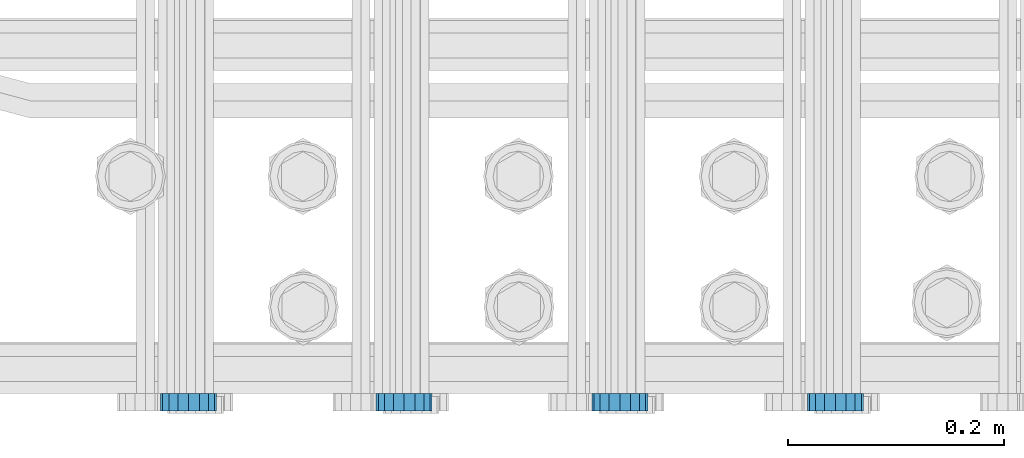
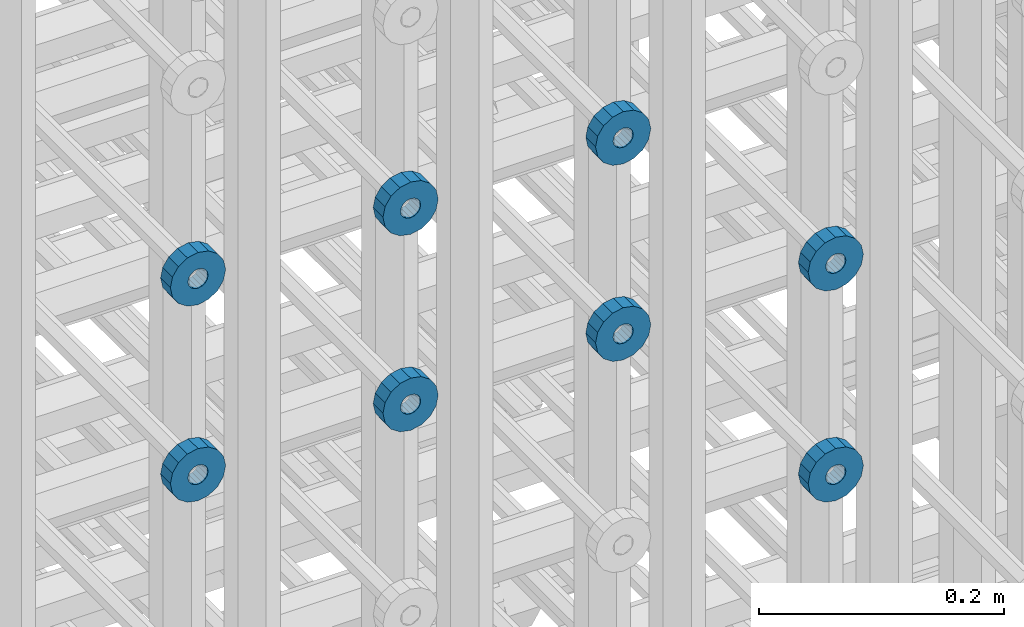
# One storey, part 117 of 177: 8 beams.
"""IFC2X3 building model written with IfcOpenShell, lengths in millimetres."""

from ifc_helpers import new_model, si_unit, frame, origin_with_axes, place, context, subcontext, project, spatial, faceted_brep, material, type_object, element, save


model = new_model("IFC2X3")

# Units and contexts
model_context_1 = context("Model", 3, precision=1e-05, world=origin_with_axes())
model_context_2 = context("Model", 3, precision=1e-05, world=origin_with_axes())
body_context = subcontext(model_context_2, "Body", "Model", "MODEL_VIEW")
ifc_project = project(units=[si_unit("LENGTHUNIT", "METRE", prefix="MILLI"), si_unit("AREAUNIT", "SQUARE_METRE"), si_unit("VOLUMEUNIT", "CUBIC_METRE"), si_unit("MASSUNIT", "GRAM", prefix="KILO"), si_unit("TIMEUNIT", "SECOND"), si_unit("PLANEANGLEUNIT", "RADIAN"), si_unit("SOLIDANGLEUNIT", "STERADIAN"), si_unit("THERMODYNAMICTEMPERATUREUNIT", "DEGREE_CELSIUS"), si_unit("LUMINOUSINTENSITYUNIT", "LUMEN")], contexts=[model_context_1])

# Site, building, storey
site_placement = place(None, origin_with_axes())
site = spatial("IfcSite", under=ifc_project, at=site_placement, CompositionType="ELEMENT")
building_placement = place(site_placement, origin_with_axes())
building = spatial("IfcBuilding", under=site, at=building_placement, Name="Undefined", CompositionType="ELEMENT")
storey_placement = place(building_placement, origin_with_axes())
storey = spatial("IfcBuildingStorey", under=building, at=storey_placement, Name="Undefined", CompositionType="ELEMENT", Elevation=0.0)

# Beams
ifc_material = material(Name="STEEL/Steel_Undefined")
beam_type = type_object("IfcBeamType", PredefinedType="NOTDEFINED")
beam_1_placement = place(storey_placement, frame((2030529.49847313, 6205075.98588032, 21954.9868114202), z_axis=(0.0, 0.0, -1.0), x_axis=(0.0, -1.0, 0.0)))
element("IfcBeam", 1, at=beam_1_placement, inside=storey, type_object=beam_type, material=ifc_material, context=body_context, shape_type="Brep", body=[
    faceted_brep([(0.0, -9.5, 0.0), (0.0, -8.77685555908829, 3.63549260746731), (16.0, -8.77685555908829, 3.63549260746731), (16.0, -9.5, 0.0), (0.0, -6.71751442085952, 6.71751442127061), (16.0, -6.71751442085952, 6.71751442127061), (0.0, -3.63549260701984, 8.77685555885546), (16.0, -3.63549260701984, 8.77685555885546), (-2.02452244836415e-12, 0.0, 9.5), (16.0, 0.0, 9.5), (0.0, 3.63549260701984, 8.77685555885546), (16.0, 3.63549260701984, 8.77685555885546), (0.0, 6.71751442085952, 6.71751442127061), (16.0, 6.71751442085952, 6.71751442127061), (0.0, 8.77685555908829, 3.63549260746731), (16.0, 8.77685555908829, 3.63549260746731), (0.0, 9.5, 0.0), (16.0, 9.5, 0.0), (0.0, 8.77685555908829, -3.63549260746731), (16.0, 8.77685555908829, -3.63549260746731), (0.0, 6.71751442085952, -6.71751442127061), (16.0, 6.71751442085952, -6.71751442127061), (0.0, 3.63549260701984, -8.77685555885546), (16.0, 3.63549260701984, -8.77685555885546), (2.02452244836415e-12, -3.69149155687865e-15, -9.5), (16.0, 0.0, -9.5), (0.0, -3.63549260701984, -8.77685555885546), (16.0, -3.63549260701984, -8.77685555885546), (0.0, -6.71751442085952, -6.71751442127061), (16.0, -6.71751442085952, -6.71751442127061), (0.0, -8.77685555908829, -3.63549260746731), (16.0, -8.77685555908829, -3.63549260746731), (0.0, -26.0, 0.0), (0.0, -24.0208678450435, -9.94976924149159), (16.0, -24.0208678450435, -9.94976924149159), (16.0, -26.0, 0.0), (0.0, -18.3847763109952, -18.3847763108497), (16.0, -18.3847763109952, -18.3847763108497), (0.0, -9.94976924173534, -24.0208678452946), (16.0, -9.94976924173534, -24.0208678452946), (0.0, 0.0, -26.0), (16.0, 0.0, -26.0), (0.0, 9.94976924173534, -24.0208678452946), (16.0, 9.94976924173534, -24.0208678452946), (0.0, 18.3847763109952, -18.3847763108497), (16.0, 18.3847763109952, -18.3847763108497), (0.0, 24.0208678450435, -9.94976924149159), (16.0, 24.0208678450435, -9.94976924149159), (0.0, 26.0, 0.0), (16.0, 26.0, 0.0), (0.0, 24.0208678450435, 9.94976924149159), (16.0, 24.0208678450435, 9.94976924149159), (0.0, 18.3847763109952, 18.3847763108497), (16.0, 18.3847763109952, 18.3847763108497), (0.0, 9.94976924173534, 24.0208678452946), (16.0, 9.94976924173534, 24.0208678452946), (0.0, 0.0, 26.0), (16.0, 0.0, 26.0), (0.0, -9.94976924173534, 24.0208678452946), (16.0, -9.94976924173534, 24.0208678452946), (0.0, -18.3847763109952, 18.3847763108497), (16.0, -18.3847763109952, 18.3847763108497), (0.0, -24.0208678450435, 9.94976924149159), (16.0, -24.0208678450435, 9.94976924149159)], [[[0, 1, 2, 3]], [[1, 4, 5, 2]], [[4, 6, 7, 5]], [[6, 8, 9, 7]], [[8, 10, 11, 9]], [[10, 12, 13, 11]], [[12, 14, 15, 13]], [[14, 16, 17, 15]], [[16, 18, 19, 17]], [[18, 20, 21, 19]], [[20, 22, 23, 21]], [[22, 24, 25, 23]], [[24, 26, 27, 25]], [[26, 28, 29, 27]], [[28, 30, 31, 29]], [[30, 0, 3, 31]], [[32, 33, 34, 35]], [[33, 36, 37, 34]], [[36, 38, 39, 37]], [[38, 40, 41, 39]], [[40, 42, 43, 41]], [[42, 44, 45, 43]], [[44, 46, 47, 45]], [[46, 48, 49, 47]], [[48, 50, 51, 49]], [[50, 52, 53, 51]], [[52, 54, 55, 53]], [[54, 56, 57, 55]], [[56, 58, 59, 57]], [[58, 60, 61, 59]], [[60, 62, 63, 61]], [[62, 32, 35, 63]], [[37, 39, 41, 43, 45, 47, 49, 51, 53, 55, 57, 59, 61, 63, 35, 34], [5, 7, 9, 11, 13, 15, 17, 19, 21, 23, 25, 27, 29, 31, 3, 2]], [[62, 60, 58, 56, 54, 52, 50, 48, 46, 44, 42, 40, 38, 36, 33, 32], [30, 28, 26, 24, 22, 20, 18, 16, 14, 12, 10, 8, 6, 4, 1, 0]]]),
])
beam_2_placement = place(storey_placement, frame((2030329.49847313, 6205075.98588032, 21954.9868114202), z_axis=(0.0, 0.0, -1.0), x_axis=(0.0, -1.0, 0.0)))
element("IfcBeam", 2, at=beam_2_placement, inside=storey, type_object=beam_type, material=ifc_material, context=body_context, shape_type="Brep", body=[
    faceted_brep([(0.0, -9.5, 0.0), (0.0, -8.77685555908829, 3.63549260746731), (16.0, -8.77685555908829, 3.63549260746731), (16.0, -9.5, 0.0), (0.0, -6.71751442085952, 6.71751442127061), (16.0, -6.71751442085952, 6.71751442127061), (0.0, -3.63549260701984, 8.77685555885546), (16.0, -3.63549260701984, 8.77685555885546), (-2.02452244836415e-12, 0.0, 9.5), (16.0, 0.0, 9.5), (0.0, 3.63549260701984, 8.77685555885546), (16.0, 3.63549260701984, 8.77685555885546), (0.0, 6.71751442085952, 6.71751442127061), (16.0, 6.71751442085952, 6.71751442127061), (0.0, 8.77685555908829, 3.63549260746731), (16.0, 8.77685555908829, 3.63549260746731), (0.0, 9.5, 0.0), (16.0, 9.5, 0.0), (0.0, 8.77685555908829, -3.63549260746731), (16.0, 8.77685555908829, -3.63549260746731), (0.0, 6.71751442085952, -6.71751442127061), (16.0, 6.71751442085952, -6.71751442127061), (0.0, 3.63549260701984, -8.77685555885546), (16.0, 3.63549260701984, -8.77685555885546), (2.02452244836415e-12, -3.69149155687865e-15, -9.5), (16.0, 0.0, -9.5), (0.0, -3.63549260701984, -8.77685555885546), (16.0, -3.63549260701984, -8.77685555885546), (0.0, -6.71751442085952, -6.71751442127061), (16.0, -6.71751442085952, -6.71751442127061), (0.0, -8.77685555908829, -3.63549260746731), (16.0, -8.77685555908829, -3.63549260746731), (0.0, -26.0, 0.0), (0.0, -24.0208678450435, -9.94976924149159), (16.0, -24.0208678450435, -9.94976924149159), (16.0, -26.0, 0.0), (0.0, -18.3847763109952, -18.3847763108497), (16.0, -18.3847763109952, -18.3847763108497), (0.0, -9.94976924173534, -24.0208678452946), (16.0, -9.94976924173534, -24.0208678452946), (0.0, 0.0, -26.0), (16.0, 0.0, -26.0), (0.0, 9.94976924173534, -24.0208678452946), (16.0, 9.94976924173534, -24.0208678452946), (0.0, 18.3847763109952, -18.3847763108497), (16.0, 18.3847763109952, -18.3847763108497), (0.0, 24.0208678450435, -9.94976924149159), (16.0, 24.0208678450435, -9.94976924149159), (0.0, 26.0, 0.0), (16.0, 26.0, 0.0), (0.0, 24.0208678450435, 9.94976924149159), (16.0, 24.0208678450435, 9.94976924149159), (0.0, 18.3847763109952, 18.3847763108497), (16.0, 18.3847763109952, 18.3847763108497), (0.0, 9.94976924173534, 24.0208678452946), (16.0, 9.94976924173534, 24.0208678452946), (0.0, 0.0, 26.0), (16.0, 0.0, 26.0), (0.0, -9.94976924173534, 24.0208678452946), (16.0, -9.94976924173534, 24.0208678452946), (0.0, -18.3847763109952, 18.3847763108497), (16.0, -18.3847763109952, 18.3847763108497), (0.0, -24.0208678450435, 9.94976924149159), (16.0, -24.0208678450435, 9.94976924149159)], [[[0, 1, 2, 3]], [[1, 4, 5, 2]], [[4, 6, 7, 5]], [[6, 8, 9, 7]], [[8, 10, 11, 9]], [[10, 12, 13, 11]], [[12, 14, 15, 13]], [[14, 16, 17, 15]], [[16, 18, 19, 17]], [[18, 20, 21, 19]], [[20, 22, 23, 21]], [[22, 24, 25, 23]], [[24, 26, 27, 25]], [[26, 28, 29, 27]], [[28, 30, 31, 29]], [[30, 0, 3, 31]], [[32, 33, 34, 35]], [[33, 36, 37, 34]], [[36, 38, 39, 37]], [[38, 40, 41, 39]], [[40, 42, 43, 41]], [[42, 44, 45, 43]], [[44, 46, 47, 45]], [[46, 48, 49, 47]], [[48, 50, 51, 49]], [[50, 52, 53, 51]], [[52, 54, 55, 53]], [[54, 56, 57, 55]], [[56, 58, 59, 57]], [[58, 60, 61, 59]], [[60, 62, 63, 61]], [[62, 32, 35, 63]], [[37, 39, 41, 43, 45, 47, 49, 51, 53, 55, 57, 59, 61, 63, 35, 34], [5, 7, 9, 11, 13, 15, 17, 19, 21, 23, 25, 27, 29, 31, 3, 2]], [[62, 60, 58, 56, 54, 52, 50, 48, 46, 44, 42, 40, 38, 36, 33, 32], [30, 28, 26, 24, 22, 20, 18, 16, 14, 12, 10, 8, 6, 4, 1, 0]]]),
])
beam_3_placement = place(storey_placement, frame((2030129.49847313, 6205075.98588032, 21954.9868114202), z_axis=(0.0, 0.0, -1.0), x_axis=(0.0, -1.0, 0.0)))
element("IfcBeam", 3, at=beam_3_placement, inside=storey, type_object=beam_type, material=ifc_material, context=body_context, shape_type="Brep", body=[
    faceted_brep([(0.0, -9.5, 0.0), (0.0, -8.77685555908829, 3.63549260746731), (16.0, -8.77685555908829, 3.63549260746731), (16.0, -9.5, 0.0), (0.0, -6.71751442085952, 6.71751442127061), (16.0, -6.71751442085952, 6.71751442127061), (0.0, -3.63549260701984, 8.77685555885546), (16.0, -3.63549260701984, 8.77685555885546), (-2.02452244836415e-12, 0.0, 9.5), (16.0, 0.0, 9.5), (0.0, 3.63549260701984, 8.77685555885546), (16.0, 3.63549260701984, 8.77685555885546), (0.0, 6.71751442085952, 6.71751442127061), (16.0, 6.71751442085952, 6.71751442127061), (0.0, 8.77685555908829, 3.63549260746731), (16.0, 8.77685555908829, 3.63549260746731), (0.0, 9.5, 0.0), (16.0, 9.5, 0.0), (0.0, 8.77685555908829, -3.63549260746731), (16.0, 8.77685555908829, -3.63549260746731), (0.0, 6.71751442085952, -6.71751442127061), (16.0, 6.71751442085952, -6.71751442127061), (0.0, 3.63549260701984, -8.77685555885546), (16.0, 3.63549260701984, -8.77685555885546), (2.02452244836415e-12, -3.69149155687865e-15, -9.5), (16.0, 0.0, -9.5), (0.0, -3.63549260701984, -8.77685555885546), (16.0, -3.63549260701984, -8.77685555885546), (0.0, -6.71751442085952, -6.71751442127061), (16.0, -6.71751442085952, -6.71751442127061), (0.0, -8.77685555908829, -3.63549260746731), (16.0, -8.77685555908829, -3.63549260746731), (0.0, -26.0, 0.0), (0.0, -24.0208678450435, -9.94976924149159), (16.0, -24.0208678450435, -9.94976924149159), (16.0, -26.0, 0.0), (0.0, -18.3847763109952, -18.3847763108497), (16.0, -18.3847763109952, -18.3847763108497), (0.0, -9.94976924173534, -24.0208678452946), (16.0, -9.94976924173534, -24.0208678452946), (0.0, 0.0, -26.0), (16.0, 0.0, -26.0), (0.0, 9.94976924173534, -24.0208678452946), (16.0, 9.94976924173534, -24.0208678452946), (0.0, 18.3847763109952, -18.3847763108497), (16.0, 18.3847763109952, -18.3847763108497), (0.0, 24.0208678450435, -9.94976924149159), (16.0, 24.0208678450435, -9.94976924149159), (0.0, 26.0, 0.0), (16.0, 26.0, 0.0), (0.0, 24.0208678450435, 9.94976924149159), (16.0, 24.0208678450435, 9.94976924149159), (0.0, 18.3847763109952, 18.3847763108497), (16.0, 18.3847763109952, 18.3847763108497), (0.0, 9.94976924173534, 24.0208678452946), (16.0, 9.94976924173534, 24.0208678452946), (0.0, 0.0, 26.0), (16.0, 0.0, 26.0), (0.0, -9.94976924173534, 24.0208678452946), (16.0, -9.94976924173534, 24.0208678452946), (0.0, -18.3847763109952, 18.3847763108497), (16.0, -18.3847763109952, 18.3847763108497), (0.0, -24.0208678450435, 9.94976924149159), (16.0, -24.0208678450435, 9.94976924149159)], [[[0, 1, 2, 3]], [[1, 4, 5, 2]], [[4, 6, 7, 5]], [[6, 8, 9, 7]], [[8, 10, 11, 9]], [[10, 12, 13, 11]], [[12, 14, 15, 13]], [[14, 16, 17, 15]], [[16, 18, 19, 17]], [[18, 20, 21, 19]], [[20, 22, 23, 21]], [[22, 24, 25, 23]], [[24, 26, 27, 25]], [[26, 28, 29, 27]], [[28, 30, 31, 29]], [[30, 0, 3, 31]], [[32, 33, 34, 35]], [[33, 36, 37, 34]], [[36, 38, 39, 37]], [[38, 40, 41, 39]], [[40, 42, 43, 41]], [[42, 44, 45, 43]], [[44, 46, 47, 45]], [[46, 48, 49, 47]], [[48, 50, 51, 49]], [[50, 52, 53, 51]], [[52, 54, 55, 53]], [[54, 56, 57, 55]], [[56, 58, 59, 57]], [[58, 60, 61, 59]], [[60, 62, 63, 61]], [[62, 32, 35, 63]], [[37, 39, 41, 43, 45, 47, 49, 51, 53, 55, 57, 59, 61, 63, 35, 34], [5, 7, 9, 11, 13, 15, 17, 19, 21, 23, 25, 27, 29, 31, 3, 2]], [[62, 60, 58, 56, 54, 52, 50, 48, 46, 44, 42, 40, 38, 36, 33, 32], [30, 28, 26, 24, 22, 20, 18, 16, 14, 12, 10, 8, 6, 4, 1, 0]]]),
])
beam_4_placement = place(storey_placement, frame((2030729.49847313, 6205075.98588607, 21759.9868126721), z_axis=(0.0, 0.0, -1.0), x_axis=(0.0, -1.0, 0.0)))
element("IfcBeam", 4, at=beam_4_placement, inside=storey, type_object=beam_type, material=ifc_material, context=body_context, shape_type="Brep", body=[
    faceted_brep([(0.0, -9.5, 0.0), (0.0, -8.77685555908829, 3.63549260746731), (16.0, -8.77685555908829, 3.63549260746731), (16.0, -9.5, 0.0), (0.0, -6.71751442085952, 6.71751442127061), (16.0, -6.71751442085952, 6.71751442127061), (0.0, -3.63549260701984, 8.77685555885546), (16.0, -3.63549260701984, 8.77685555885546), (-2.02452244836415e-12, 0.0, 9.5), (16.0, 0.0, 9.5), (0.0, 3.63549260701984, 8.77685555885546), (16.0, 3.63549260701984, 8.77685555885546), (0.0, 6.71751442085952, 6.71751442127061), (16.0, 6.71751442085952, 6.71751442127061), (0.0, 8.77685555908829, 3.63549260746731), (16.0, 8.77685555908829, 3.63549260746731), (0.0, 9.5, 0.0), (16.0, 9.5, 0.0), (0.0, 8.77685555908829, -3.63549260746731), (16.0, 8.77685555908829, -3.63549260746731), (0.0, 6.71751442085952, -6.71751442127061), (16.0, 6.71751442085952, -6.71751442127061), (0.0, 3.63549260701984, -8.77685555885546), (16.0, 3.63549260701984, -8.77685555885546), (2.02452244836415e-12, -3.69149155687865e-15, -9.5), (16.0, 0.0, -9.5), (0.0, -3.63549260701984, -8.77685555885546), (16.0, -3.63549260701984, -8.77685555885546), (0.0, -6.71751442085952, -6.71751442127061), (16.0, -6.71751442085952, -6.71751442127061), (0.0, -8.77685555908829, -3.63549260746731), (16.0, -8.77685555908829, -3.63549260746731), (0.0, -26.0, 0.0), (0.0, -24.0208678450435, -9.94976924149159), (16.0, -24.0208678450435, -9.94976924149159), (16.0, -26.0, 0.0), (0.0, -18.3847763109952, -18.3847763108497), (16.0, -18.3847763109952, -18.3847763108497), (0.0, -9.94976924173534, -24.0208678452946), (16.0, -9.94976924173534, -24.0208678452946), (0.0, 0.0, -26.0), (16.0, 0.0, -26.0), (0.0, 9.94976924173534, -24.0208678452946), (16.0, 9.94976924173534, -24.0208678452946), (0.0, 18.3847763109952, -18.3847763108497), (16.0, 18.3847763109952, -18.3847763108497), (0.0, 24.0208678450435, -9.94976924149159), (16.0, 24.0208678450435, -9.94976924149159), (0.0, 26.0, 0.0), (16.0, 26.0, 0.0), (0.0, 24.0208678450435, 9.94976924149159), (16.0, 24.0208678450435, 9.94976924149159), (0.0, 18.3847763109952, 18.3847763108497), (16.0, 18.3847763109952, 18.3847763108497), (0.0, 9.94976924173534, 24.0208678452946), (16.0, 9.94976924173534, 24.0208678452946), (0.0, 0.0, 26.0), (16.0, 0.0, 26.0), (0.0, -9.94976924173534, 24.0208678452946), (16.0, -9.94976924173534, 24.0208678452946), (0.0, -18.3847763109952, 18.3847763108497), (16.0, -18.3847763109952, 18.3847763108497), (0.0, -24.0208678450435, 9.94976924149159), (16.0, -24.0208678450435, 9.94976924149159)], [[[0, 1, 2, 3]], [[1, 4, 5, 2]], [[4, 6, 7, 5]], [[6, 8, 9, 7]], [[8, 10, 11, 9]], [[10, 12, 13, 11]], [[12, 14, 15, 13]], [[14, 16, 17, 15]], [[16, 18, 19, 17]], [[18, 20, 21, 19]], [[20, 22, 23, 21]], [[22, 24, 25, 23]], [[24, 26, 27, 25]], [[26, 28, 29, 27]], [[28, 30, 31, 29]], [[30, 0, 3, 31]], [[32, 33, 34, 35]], [[33, 36, 37, 34]], [[36, 38, 39, 37]], [[38, 40, 41, 39]], [[40, 42, 43, 41]], [[42, 44, 45, 43]], [[44, 46, 47, 45]], [[46, 48, 49, 47]], [[48, 50, 51, 49]], [[50, 52, 53, 51]], [[52, 54, 55, 53]], [[54, 56, 57, 55]], [[56, 58, 59, 57]], [[58, 60, 61, 59]], [[60, 62, 63, 61]], [[62, 32, 35, 63]], [[37, 39, 41, 43, 45, 47, 49, 51, 53, 55, 57, 59, 61, 63, 35, 34], [5, 7, 9, 11, 13, 15, 17, 19, 21, 23, 25, 27, 29, 31, 3, 2]], [[62, 60, 58, 56, 54, 52, 50, 48, 46, 44, 42, 40, 38, 36, 33, 32], [30, 28, 26, 24, 22, 20, 18, 16, 14, 12, 10, 8, 6, 4, 1, 0]]]),
])
beam_5_placement = place(storey_placement, frame((2030529.49847313, 6205075.98588607, 21759.9868126721), z_axis=(0.0, 0.0, -1.0), x_axis=(0.0, -1.0, 0.0)))
element("IfcBeam", 5, at=beam_5_placement, inside=storey, type_object=beam_type, material=ifc_material, context=body_context, shape_type="Brep", body=[
    faceted_brep([(0.0, -9.5, 0.0), (0.0, -8.77685555908829, 3.63549260746731), (16.0, -8.77685555908829, 3.63549260746731), (16.0, -9.5, 0.0), (0.0, -6.71751442085952, 6.71751442127061), (16.0, -6.71751442085952, 6.71751442127061), (0.0, -3.63549260701984, 8.77685555885546), (16.0, -3.63549260701984, 8.77685555885546), (-2.02452244836415e-12, 0.0, 9.5), (16.0, 0.0, 9.5), (0.0, 3.63549260701984, 8.77685555885546), (16.0, 3.63549260701984, 8.77685555885546), (0.0, 6.71751442085952, 6.71751442127061), (16.0, 6.71751442085952, 6.71751442127061), (0.0, 8.77685555908829, 3.63549260746731), (16.0, 8.77685555908829, 3.63549260746731), (0.0, 9.5, 0.0), (16.0, 9.5, 0.0), (0.0, 8.77685555908829, -3.63549260746731), (16.0, 8.77685555908829, -3.63549260746731), (0.0, 6.71751442085952, -6.71751442127061), (16.0, 6.71751442085952, -6.71751442127061), (0.0, 3.63549260701984, -8.77685555885546), (16.0, 3.63549260701984, -8.77685555885546), (2.02452244836415e-12, -3.69149155687865e-15, -9.5), (16.0, 0.0, -9.5), (0.0, -3.63549260701984, -8.77685555885546), (16.0, -3.63549260701984, -8.77685555885546), (0.0, -6.71751442085952, -6.71751442127061), (16.0, -6.71751442085952, -6.71751442127061), (0.0, -8.77685555908829, -3.63549260746731), (16.0, -8.77685555908829, -3.63549260746731), (0.0, -26.0, 0.0), (0.0, -24.0208678450435, -9.94976924149159), (16.0, -24.0208678450435, -9.94976924149159), (16.0, -26.0, 0.0), (0.0, -18.3847763109952, -18.3847763108497), (16.0, -18.3847763109952, -18.3847763108497), (0.0, -9.94976924173534, -24.0208678452946), (16.0, -9.94976924173534, -24.0208678452946), (0.0, 0.0, -26.0), (16.0, 0.0, -26.0), (0.0, 9.94976924173534, -24.0208678452946), (16.0, 9.94976924173534, -24.0208678452946), (0.0, 18.3847763109952, -18.3847763108497), (16.0, 18.3847763109952, -18.3847763108497), (0.0, 24.0208678450435, -9.94976924149159), (16.0, 24.0208678450435, -9.94976924149159), (0.0, 26.0, 0.0), (16.0, 26.0, 0.0), (0.0, 24.0208678450435, 9.94976924149159), (16.0, 24.0208678450435, 9.94976924149159), (0.0, 18.3847763109952, 18.3847763108497), (16.0, 18.3847763109952, 18.3847763108497), (0.0, 9.94976924173534, 24.0208678452946), (16.0, 9.94976924173534, 24.0208678452946), (0.0, 0.0, 26.0), (16.0, 0.0, 26.0), (0.0, -9.94976924173534, 24.0208678452946), (16.0, -9.94976924173534, 24.0208678452946), (0.0, -18.3847763109952, 18.3847763108497), (16.0, -18.3847763109952, 18.3847763108497), (0.0, -24.0208678450435, 9.94976924149159), (16.0, -24.0208678450435, 9.94976924149159)], [[[0, 1, 2, 3]], [[1, 4, 5, 2]], [[4, 6, 7, 5]], [[6, 8, 9, 7]], [[8, 10, 11, 9]], [[10, 12, 13, 11]], [[12, 14, 15, 13]], [[14, 16, 17, 15]], [[16, 18, 19, 17]], [[18, 20, 21, 19]], [[20, 22, 23, 21]], [[22, 24, 25, 23]], [[24, 26, 27, 25]], [[26, 28, 29, 27]], [[28, 30, 31, 29]], [[30, 0, 3, 31]], [[32, 33, 34, 35]], [[33, 36, 37, 34]], [[36, 38, 39, 37]], [[38, 40, 41, 39]], [[40, 42, 43, 41]], [[42, 44, 45, 43]], [[44, 46, 47, 45]], [[46, 48, 49, 47]], [[48, 50, 51, 49]], [[50, 52, 53, 51]], [[52, 54, 55, 53]], [[54, 56, 57, 55]], [[56, 58, 59, 57]], [[58, 60, 61, 59]], [[60, 62, 63, 61]], [[62, 32, 35, 63]], [[37, 39, 41, 43, 45, 47, 49, 51, 53, 55, 57, 59, 61, 63, 35, 34], [5, 7, 9, 11, 13, 15, 17, 19, 21, 23, 25, 27, 29, 31, 3, 2]], [[62, 60, 58, 56, 54, 52, 50, 48, 46, 44, 42, 40, 38, 36, 33, 32], [30, 28, 26, 24, 22, 20, 18, 16, 14, 12, 10, 8, 6, 4, 1, 0]]]),
])
beam_6_placement = place(storey_placement, frame((2030329.49847313, 6205075.98588607, 21759.9868126721), z_axis=(0.0, 0.0, -1.0), x_axis=(0.0, -1.0, 0.0)))
element("IfcBeam", 6, at=beam_6_placement, inside=storey, type_object=beam_type, material=ifc_material, context=body_context, shape_type="Brep", body=[
    faceted_brep([(0.0, -9.5, 0.0), (0.0, -8.77685555908829, 3.63549260746731), (16.0, -8.77685555908829, 3.63549260746731), (16.0, -9.5, 0.0), (0.0, -6.71751442085952, 6.71751442127061), (16.0, -6.71751442085952, 6.71751442127061), (0.0, -3.63549260701984, 8.77685555885546), (16.0, -3.63549260701984, 8.77685555885546), (-2.02452244836415e-12, 0.0, 9.5), (16.0, 0.0, 9.5), (0.0, 3.63549260701984, 8.77685555885546), (16.0, 3.63549260701984, 8.77685555885546), (0.0, 6.71751442085952, 6.71751442127061), (16.0, 6.71751442085952, 6.71751442127061), (0.0, 8.77685555908829, 3.63549260746731), (16.0, 8.77685555908829, 3.63549260746731), (0.0, 9.5, 0.0), (16.0, 9.5, 0.0), (0.0, 8.77685555908829, -3.63549260746731), (16.0, 8.77685555908829, -3.63549260746731), (0.0, 6.71751442085952, -6.71751442127061), (16.0, 6.71751442085952, -6.71751442127061), (0.0, 3.63549260701984, -8.77685555885546), (16.0, 3.63549260701984, -8.77685555885546), (2.02452244836415e-12, -3.69149155687865e-15, -9.5), (16.0, 0.0, -9.5), (0.0, -3.63549260701984, -8.77685555885546), (16.0, -3.63549260701984, -8.77685555885546), (0.0, -6.71751442085952, -6.71751442127061), (16.0, -6.71751442085952, -6.71751442127061), (0.0, -8.77685555908829, -3.63549260746731), (16.0, -8.77685555908829, -3.63549260746731), (0.0, -26.0, 0.0), (0.0, -24.0208678450435, -9.94976924149159), (16.0, -24.0208678450435, -9.94976924149159), (16.0, -26.0, 0.0), (0.0, -18.3847763109952, -18.3847763108497), (16.0, -18.3847763109952, -18.3847763108497), (0.0, -9.94976924173534, -24.0208678452946), (16.0, -9.94976924173534, -24.0208678452946), (0.0, 0.0, -26.0), (16.0, 0.0, -26.0), (0.0, 9.94976924173534, -24.0208678452946), (16.0, 9.94976924173534, -24.0208678452946), (0.0, 18.3847763109952, -18.3847763108497), (16.0, 18.3847763109952, -18.3847763108497), (0.0, 24.0208678450435, -9.94976924149159), (16.0, 24.0208678450435, -9.94976924149159), (0.0, 26.0, 0.0), (16.0, 26.0, 0.0), (0.0, 24.0208678450435, 9.94976924149159), (16.0, 24.0208678450435, 9.94976924149159), (0.0, 18.3847763109952, 18.3847763108497), (16.0, 18.3847763109952, 18.3847763108497), (0.0, 9.94976924173534, 24.0208678452946), (16.0, 9.94976924173534, 24.0208678452946), (0.0, 0.0, 26.0), (16.0, 0.0, 26.0), (0.0, -9.94976924173534, 24.0208678452946), (16.0, -9.94976924173534, 24.0208678452946), (0.0, -18.3847763109952, 18.3847763108497), (16.0, -18.3847763109952, 18.3847763108497), (0.0, -24.0208678450435, 9.94976924149159), (16.0, -24.0208678450435, 9.94976924149159)], [[[0, 1, 2, 3]], [[1, 4, 5, 2]], [[4, 6, 7, 5]], [[6, 8, 9, 7]], [[8, 10, 11, 9]], [[10, 12, 13, 11]], [[12, 14, 15, 13]], [[14, 16, 17, 15]], [[16, 18, 19, 17]], [[18, 20, 21, 19]], [[20, 22, 23, 21]], [[22, 24, 25, 23]], [[24, 26, 27, 25]], [[26, 28, 29, 27]], [[28, 30, 31, 29]], [[30, 0, 3, 31]], [[32, 33, 34, 35]], [[33, 36, 37, 34]], [[36, 38, 39, 37]], [[38, 40, 41, 39]], [[40, 42, 43, 41]], [[42, 44, 45, 43]], [[44, 46, 47, 45]], [[46, 48, 49, 47]], [[48, 50, 51, 49]], [[50, 52, 53, 51]], [[52, 54, 55, 53]], [[54, 56, 57, 55]], [[56, 58, 59, 57]], [[58, 60, 61, 59]], [[60, 62, 63, 61]], [[62, 32, 35, 63]], [[37, 39, 41, 43, 45, 47, 49, 51, 53, 55, 57, 59, 61, 63, 35, 34], [5, 7, 9, 11, 13, 15, 17, 19, 21, 23, 25, 27, 29, 31, 3, 2]], [[62, 60, 58, 56, 54, 52, 50, 48, 46, 44, 42, 40, 38, 36, 33, 32], [30, 28, 26, 24, 22, 20, 18, 16, 14, 12, 10, 8, 6, 4, 1, 0]]]),
])
beam_7_placement = place(storey_placement, frame((2030129.49847313, 6205075.98588607, 21759.9868126721), z_axis=(0.0, 0.0, -1.0), x_axis=(0.0, -1.0, 0.0)))
element("IfcBeam", 7, at=beam_7_placement, inside=storey, type_object=beam_type, material=ifc_material, context=body_context, shape_type="Brep", body=[
    faceted_brep([(0.0, -9.5, 0.0), (0.0, -8.77685555908829, 3.63549260746731), (16.0, -8.77685555908829, 3.63549260746731), (16.0, -9.5, 0.0), (0.0, -6.71751442085952, 6.71751442127061), (16.0, -6.71751442085952, 6.71751442127061), (0.0, -3.63549260701984, 8.77685555885546), (16.0, -3.63549260701984, 8.77685555885546), (-2.02452244836415e-12, 0.0, 9.5), (16.0, 0.0, 9.5), (0.0, 3.63549260701984, 8.77685555885546), (16.0, 3.63549260701984, 8.77685555885546), (0.0, 6.71751442085952, 6.71751442127061), (16.0, 6.71751442085952, 6.71751442127061), (0.0, 8.77685555908829, 3.63549260746731), (16.0, 8.77685555908829, 3.63549260746731), (0.0, 9.5, 0.0), (16.0, 9.5, 0.0), (0.0, 8.77685555908829, -3.63549260746731), (16.0, 8.77685555908829, -3.63549260746731), (0.0, 6.71751442085952, -6.71751442127061), (16.0, 6.71751442085952, -6.71751442127061), (0.0, 3.63549260701984, -8.77685555885546), (16.0, 3.63549260701984, -8.77685555885546), (2.02452244836415e-12, -3.69149155687865e-15, -9.5), (16.0, 0.0, -9.5), (0.0, -3.63549260701984, -8.77685555885546), (16.0, -3.63549260701984, -8.77685555885546), (0.0, -6.71751442085952, -6.71751442127061), (16.0, -6.71751442085952, -6.71751442127061), (0.0, -8.77685555908829, -3.63549260746731), (16.0, -8.77685555908829, -3.63549260746731), (0.0, -26.0, 0.0), (0.0, -24.0208678450435, -9.94976924149159), (16.0, -24.0208678450435, -9.94976924149159), (16.0, -26.0, 0.0), (0.0, -18.3847763109952, -18.3847763108497), (16.0, -18.3847763109952, -18.3847763108497), (0.0, -9.94976924173534, -24.0208678452946), (16.0, -9.94976924173534, -24.0208678452946), (0.0, 0.0, -26.0), (16.0, 0.0, -26.0), (0.0, 9.94976924173534, -24.0208678452946), (16.0, 9.94976924173534, -24.0208678452946), (0.0, 18.3847763109952, -18.3847763108497), (16.0, 18.3847763109952, -18.3847763108497), (0.0, 24.0208678450435, -9.94976924149159), (16.0, 24.0208678450435, -9.94976924149159), (0.0, 26.0, 0.0), (16.0, 26.0, 0.0), (0.0, 24.0208678450435, 9.94976924149159), (16.0, 24.0208678450435, 9.94976924149159), (0.0, 18.3847763109952, 18.3847763108497), (16.0, 18.3847763109952, 18.3847763108497), (0.0, 9.94976924173534, 24.0208678452946), (16.0, 9.94976924173534, 24.0208678452946), (0.0, 0.0, 26.0), (16.0, 0.0, 26.0), (0.0, -9.94976924173534, 24.0208678452946), (16.0, -9.94976924173534, 24.0208678452946), (0.0, -18.3847763109952, 18.3847763108497), (16.0, -18.3847763109952, 18.3847763108497), (0.0, -24.0208678450435, 9.94976924149159), (16.0, -24.0208678450435, 9.94976924149159)], [[[0, 1, 2, 3]], [[1, 4, 5, 2]], [[4, 6, 7, 5]], [[6, 8, 9, 7]], [[8, 10, 11, 9]], [[10, 12, 13, 11]], [[12, 14, 15, 13]], [[14, 16, 17, 15]], [[16, 18, 19, 17]], [[18, 20, 21, 19]], [[20, 22, 23, 21]], [[22, 24, 25, 23]], [[24, 26, 27, 25]], [[26, 28, 29, 27]], [[28, 30, 31, 29]], [[30, 0, 3, 31]], [[32, 33, 34, 35]], [[33, 36, 37, 34]], [[36, 38, 39, 37]], [[38, 40, 41, 39]], [[40, 42, 43, 41]], [[42, 44, 45, 43]], [[44, 46, 47, 45]], [[46, 48, 49, 47]], [[48, 50, 51, 49]], [[50, 52, 53, 51]], [[52, 54, 55, 53]], [[54, 56, 57, 55]], [[56, 58, 59, 57]], [[58, 60, 61, 59]], [[60, 62, 63, 61]], [[62, 32, 35, 63]], [[37, 39, 41, 43, 45, 47, 49, 51, 53, 55, 57, 59, 61, 63, 35, 34], [5, 7, 9, 11, 13, 15, 17, 19, 21, 23, 25, 27, 29, 31, 3, 2]], [[62, 60, 58, 56, 54, 52, 50, 48, 46, 44, 42, 40, 38, 36, 33, 32], [30, 28, 26, 24, 22, 20, 18, 16, 14, 12, 10, 8, 6, 4, 1, 0]]]),
])
beam_8_placement = place(storey_placement, frame((2030729.49847313, 6205075.98588592, 21549.9868126721), z_axis=(0.0, 0.0, -1.0), x_axis=(0.0, -1.0, 0.0)))
element("IfcBeam", 8, at=beam_8_placement, inside=storey, type_object=beam_type, material=ifc_material, context=body_context, shape_type="Brep", body=[
    faceted_brep([(0.0, -9.5, 0.0), (0.0, -8.77685555908829, 3.63549260746731), (16.0, -8.77685555908829, 3.63549260746731), (16.0, -9.5, 0.0), (0.0, -6.71751442085952, 6.71751442127061), (16.0, -6.71751442085952, 6.71751442127061), (0.0, -3.63549260701984, 8.77685555885546), (16.0, -3.63549260701984, 8.77685555885546), (-2.02452244836415e-12, 0.0, 9.5), (16.0, 0.0, 9.5), (0.0, 3.63549260701984, 8.77685555885546), (16.0, 3.63549260701984, 8.77685555885546), (0.0, 6.71751442085952, 6.71751442127061), (16.0, 6.71751442085952, 6.71751442127061), (0.0, 8.77685555908829, 3.63549260746731), (16.0, 8.77685555908829, 3.63549260746731), (0.0, 9.5, 0.0), (16.0, 9.5, 0.0), (0.0, 8.77685555908829, -3.63549260746731), (16.0, 8.77685555908829, -3.63549260746731), (0.0, 6.71751442085952, -6.71751442127061), (16.0, 6.71751442085952, -6.71751442127061), (0.0, 3.63549260701984, -8.77685555885546), (16.0, 3.63549260701984, -8.77685555885546), (2.02452244836415e-12, -3.69149155687865e-15, -9.5), (16.0, 0.0, -9.5), (0.0, -3.63549260701984, -8.77685555885546), (16.0, -3.63549260701984, -8.77685555885546), (0.0, -6.71751442085952, -6.71751442127061), (16.0, -6.71751442085952, -6.71751442127061), (0.0, -8.77685555908829, -3.63549260746731), (16.0, -8.77685555908829, -3.63549260746731), (0.0, -26.0, 0.0), (0.0, -24.0208678450435, -9.94976924149159), (16.0, -24.0208678450435, -9.94976924149159), (16.0, -26.0, 0.0), (0.0, -18.3847763109952, -18.3847763108497), (16.0, -18.3847763109952, -18.3847763108497), (0.0, -9.94976924173534, -24.0208678452946), (16.0, -9.94976924173534, -24.0208678452946), (0.0, 0.0, -26.0), (16.0, 0.0, -26.0), (0.0, 9.94976924173534, -24.0208678452946), (16.0, 9.94976924173534, -24.0208678452946), (0.0, 18.3847763109952, -18.3847763108497), (16.0, 18.3847763109952, -18.3847763108497), (0.0, 24.0208678450435, -9.94976924149159), (16.0, 24.0208678450435, -9.94976924149159), (0.0, 26.0, 0.0), (16.0, 26.0, 0.0), (0.0, 24.0208678450435, 9.94976924149159), (16.0, 24.0208678450435, 9.94976924149159), (0.0, 18.3847763109952, 18.3847763108497), (16.0, 18.3847763109952, 18.3847763108497), (0.0, 9.94976924173534, 24.0208678452946), (16.0, 9.94976924173534, 24.0208678452946), (0.0, 0.0, 26.0), (16.0, 0.0, 26.0), (0.0, -9.94976924173534, 24.0208678452946), (16.0, -9.94976924173534, 24.0208678452946), (0.0, -18.3847763109952, 18.3847763108497), (16.0, -18.3847763109952, 18.3847763108497), (0.0, -24.0208678450435, 9.94976924149159), (16.0, -24.0208678450435, 9.94976924149159)], [[[0, 1, 2, 3]], [[1, 4, 5, 2]], [[4, 6, 7, 5]], [[6, 8, 9, 7]], [[8, 10, 11, 9]], [[10, 12, 13, 11]], [[12, 14, 15, 13]], [[14, 16, 17, 15]], [[16, 18, 19, 17]], [[18, 20, 21, 19]], [[20, 22, 23, 21]], [[22, 24, 25, 23]], [[24, 26, 27, 25]], [[26, 28, 29, 27]], [[28, 30, 31, 29]], [[30, 0, 3, 31]], [[32, 33, 34, 35]], [[33, 36, 37, 34]], [[36, 38, 39, 37]], [[38, 40, 41, 39]], [[40, 42, 43, 41]], [[42, 44, 45, 43]], [[44, 46, 47, 45]], [[46, 48, 49, 47]], [[48, 50, 51, 49]], [[50, 52, 53, 51]], [[52, 54, 55, 53]], [[54, 56, 57, 55]], [[56, 58, 59, 57]], [[58, 60, 61, 59]], [[60, 62, 63, 61]], [[62, 32, 35, 63]], [[37, 39, 41, 43, 45, 47, 49, 51, 53, 55, 57, 59, 61, 63, 35, 34], [5, 7, 9, 11, 13, 15, 17, 19, 21, 23, 25, 27, 29, 31, 3, 2]], [[62, 60, 58, 56, 54, 52, 50, 48, 46, 44, 42, 40, 38, 36, 33, 32], [30, 28, 26, 24, 22, 20, 18, 16, 14, 12, 10, 8, 6, 4, 1, 0]]]),
])

save(model, "model.ifc")
